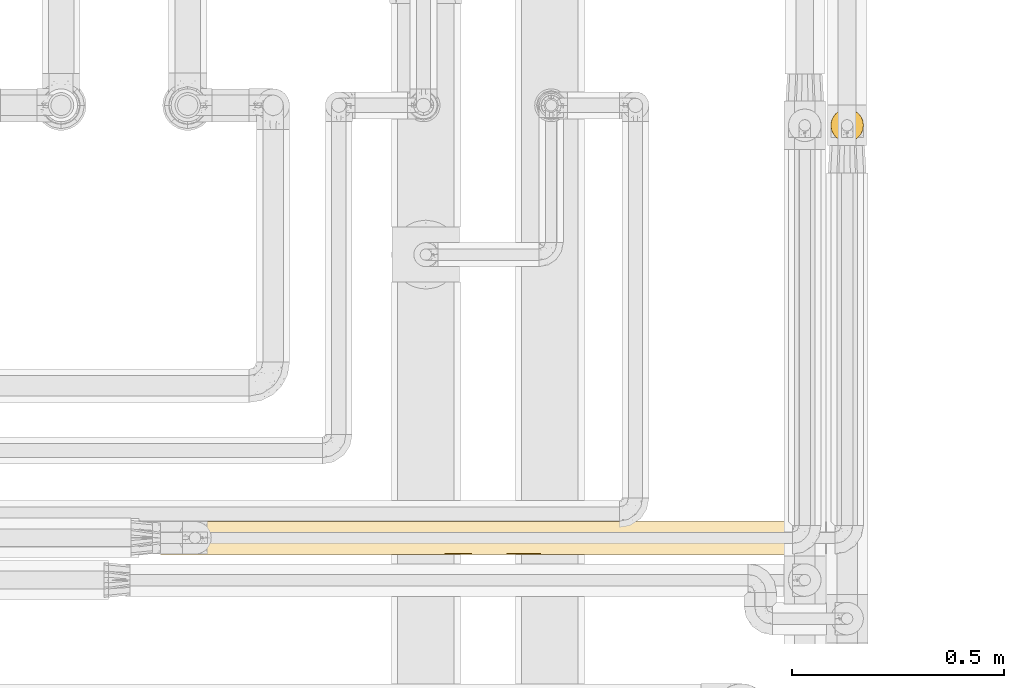
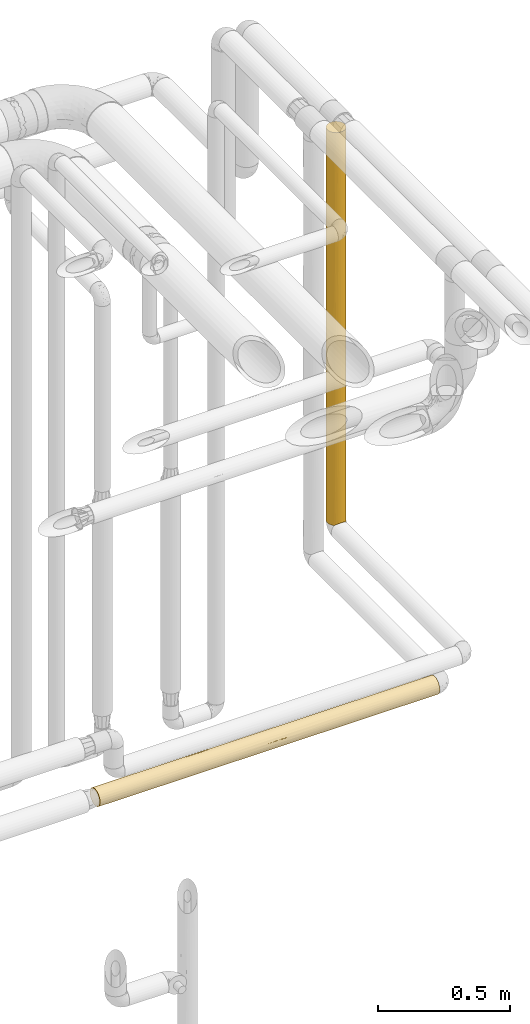
# One storey, part 50 of 827: 2 coverings.
"""IFC2X3 building model written with IfcOpenShell, lengths in millimetres."""

from ifc_helpers import new_model, entity, si_unit, converted_unit, derived_unit, direction, frame, origin, place, context, subcontext, project, spatial, faceted_brep, element, save


model = new_model("IFC2X3")

# Units and contexts
model_context = context("Model", 3, precision=0.01, world=origin(), true_north=direction((6.12303176911189e-17, 1.0)))
body_context = subcontext(model_context, "Body", "Model", "MODEL_VIEW")
ifc_project = project(units=[si_unit("LENGTHUNIT", "METRE", prefix="MILLI"), si_unit("AREAUNIT", "SQUARE_METRE"), si_unit("VOLUMEUNIT", "CUBIC_METRE"), converted_unit("PLANEANGLEUNIT", "DEGREE", entity("IfcRatioMeasure", 0.0174532925199433), si_unit("PLANEANGLEUNIT", "RADIAN"), dimensions=[0, 0, 0, 0, 0, 0, 0]), si_unit("MASSUNIT", "GRAM", prefix="KILO"), derived_unit("MASSDENSITYUNIT", [(si_unit("MASSUNIT", "GRAM", prefix="KILO"), 1), (si_unit("LENGTHUNIT", "METRE"), -3)]), derived_unit("MOMENTOFINERTIAUNIT", [(si_unit("LENGTHUNIT", "METRE"), 4)]), si_unit("TIMEUNIT", "SECOND"), si_unit("FREQUENCYUNIT", "HERTZ"), si_unit("THERMODYNAMICTEMPERATUREUNIT", "DEGREE_CELSIUS"), derived_unit("THERMALTRANSMITTANCEUNIT", [(si_unit("MASSUNIT", "GRAM", prefix="KILO"), 1), (si_unit("THERMODYNAMICTEMPERATUREUNIT", "KELVIN"), -1), (si_unit("TIMEUNIT", "SECOND"), -3)]), derived_unit("VOLUMETRICFLOWRATEUNIT", [(si_unit("LENGTHUNIT", "METRE"), 3), (si_unit("TIMEUNIT", "SECOND"), -1)]), derived_unit("MASSFLOWRATEUNIT", [(si_unit("MASSUNIT", "GRAM", prefix="KILO"), 1), (si_unit("TIMEUNIT", "SECOND"), -1)]), derived_unit("ROTATIONALFREQUENCYUNIT", [(si_unit("TIMEUNIT", "SECOND"), -1)]), si_unit("ELECTRICCURRENTUNIT", "AMPERE"), si_unit("ELECTRICVOLTAGEUNIT", "VOLT"), si_unit("POWERUNIT", "WATT"), si_unit("FORCEUNIT", "NEWTON", prefix="KILO"), si_unit("ILLUMINANCEUNIT", "LUX"), si_unit("LUMINOUSFLUXUNIT", "LUMEN"), si_unit("LUMINOUSINTENSITYUNIT", "CANDELA"), derived_unit("USERDEFINED", [(si_unit("MASSUNIT", "GRAM", prefix="KILO"), -1), (si_unit("LENGTHUNIT", "METRE"), -2), (si_unit("TIMEUNIT", "SECOND"), 3), (si_unit("LUMINOUSFLUXUNIT", "LUMEN"), 1)]), derived_unit("LINEARVELOCITYUNIT", [(si_unit("LENGTHUNIT", "METRE"), 1), (si_unit("TIMEUNIT", "SECOND"), -1)]), si_unit("PRESSUREUNIT", "PASCAL"), derived_unit("USERDEFINED", [(si_unit("LENGTHUNIT", "METRE"), -2), (si_unit("MASSUNIT", "GRAM", prefix="KILO"), 1), (si_unit("TIMEUNIT", "SECOND"), -2)]), derived_unit("LINEARFORCEUNIT", [(si_unit("MASSUNIT", "GRAM", prefix="KILO"), 1), (si_unit("LENGTHUNIT", "METRE"), 1), (si_unit("TIMEUNIT", "SECOND"), -2), (si_unit("LENGTHUNIT", "METRE"), -1)]), derived_unit("PLANARFORCEUNIT", [(si_unit("MASSUNIT", "GRAM", prefix="KILO"), 1), (si_unit("LENGTHUNIT", "METRE"), 1), (si_unit("TIMEUNIT", "SECOND"), -2), (si_unit("LENGTHUNIT", "METRE"), -2)])], contexts=[model_context])

# Site, building, storey
site_placement = place(None, origin())
site = spatial("IfcSite", under=ifc_project, at=site_placement, CompositionType="ELEMENT")
building_placement = place(site_placement, origin())
building = spatial("IfcBuilding", under=site, at=building_placement, CompositionType="ELEMENT")
storey_placement = place(building_placement, frame((0.0, 0.0, 28200.0)))
storey = spatial("IfcBuildingStorey", under=building, at=storey_placement, Name="08", CompositionType="ELEMENT", Elevation=28200.0)

# Coverings
covering_1_placement = place(storey_placement, frame((61112.64, 17412.84, 1127.5)))
element("IfcCovering", 1, at=covering_1_placement, inside=storey, Name=":ADSK_", ObjectType=":ADSK_", PredefinedType="INSULATION", context=body_context, shape_type="Brep", body=[
    faceted_brep([(2.48, 31.79, 1.6), (1.6, 40.0, 1.6), (2.9, 49.93, 1.6), (6.74, 59.2, 1.6), (12.84, 67.15, 1.6), (20.8, 73.25, 1.6), (30.06, 77.09, 1.6), (40.0, 78.4, 1.6), (49.93, 77.09, 1.6), (59.2, 73.25, 1.6), (67.15, 67.15, 1.6), (73.25, 59.2, 1.6), (77.09, 49.93, 1.6), (78.4, 40.0, 1.6), (77.51, 31.79, 1.6), (74.9, 23.98, 1.6), (70.68, 16.91, 1.6), (65.05, 10.9, 1.6), (14.94, 10.9, 1.6), (9.31, 16.91, 1.6), (5.09, 23.98, 1.6), (6.74, 20.8, 1824.24), (12.84, 12.84, 1824.24), (20.8, 6.74, 1824.24), (30.06, 2.9, 1824.24), (40.0, 1.6, 1824.24), (49.93, 2.9, 1824.24), (59.2, 6.74, 1824.24), (67.15, 12.84, 1824.24), (73.25, 20.8, 1824.24), (77.09, 30.06, 1824.24), (78.4, 40.0, 1824.24), (77.09, 49.93, 1824.24), (73.25, 59.2, 1824.24), (67.15, 67.15, 1824.24), (59.2, 73.25, 1824.24), (49.93, 77.09, 1824.24), (40.0, 78.4, 1824.24), (30.06, 77.09, 1824.24), (20.8, 73.25, 1824.24), (12.84, 67.15, 1824.24), (6.74, 59.2, 1824.24), (2.9, 49.93, 1824.24), (1.6, 40.0, 1824.24), (2.9, 30.06, 1824.24), (70.46, 16.62, 1571.65), (48.24, 2.49, 335.45), (50.46, 3.05, 688.07), (40.0, 1.6, 443.64), (40.0, 1.6, 1607.87), (47.32, 2.3, 1499.68), (70.46, 16.62, 1236.43), (63.37, 9.53, 1542.38), (62.5, 8.88, 1222.44), (77.74, 32.94, 1499.68), (75.47, 25.3, 1476.79), (53.24, 3.95, 1628.84), (67.73, 13.43, 544.14), (68.03, 13.75, 287.24), (72.98, 20.33, 485.18), (76.41, 27.82, 287.23), (74.66, 23.47, 675.76), (77.14, 30.25, 616.82), (72.98, 20.33, 218.66), (53.36, 4.0, 8.5), (59.51, 6.92, 5.57), (62.48, 8.86, 194.06), (67.04, 12.73, 973.09), (62.77, 9.08, 717.19), (68.28, 14.03, 761.11), (63.21, 9.41, 406.86), (40.0, 1.6, 1391.49), (48.72, 2.6, 1275.86), (51.06, 3.22, 1059.26), (54.69, 4.52, 1413.92), (46.78, 2.2, 10.29), (78.4, 40.0, 217.97), (78.4, 40.0, 1391.49), (77.14, 30.27, 1124.85), (40.0, 1.6, 227.27), (40.0, 1.6, 10.9), (40.0, 1.6, 876.39), (40.0, 1.6, 660.01), (56.68, 5.41, 384.99), (78.4, 40.0, 434.34), (73.3, 20.88, 875.08), (74.73, 23.63, 1245.66), (78.4, 40.0, 1607.87), (57.11, 5.62, 606.06), (59.51, 6.92, 967.7), (78.4, 40.0, 650.71), (78.4, 40.0, 696.55), (78.4, 40.0, 867.09), (78.4, 40.0, 958.74), (78.4, 40.0, 1129.29), (78.4, 40.0, 1175.12), (76.8, 29.04, 870.88), (40.0, 1.6, 1133.94), (32.67, 2.3, 1499.68), (26.75, 3.95, 1628.84), (25.3, 4.52, 1413.92), (12.95, 12.73, 973.09), (20.48, 6.92, 967.7), (17.49, 8.88, 1222.44), (22.88, 5.62, 606.06), (29.53, 3.05, 688.07), (16.62, 9.53, 1542.38), (9.53, 16.62, 1571.65), (9.53, 16.62, 1236.43), (26.63, 4.0, 8.5), (23.31, 5.41, 384.99), (17.51, 8.86, 194.06), (7.01, 20.33, 218.66), (31.75, 2.49, 335.45), (33.21, 2.2, 10.29), (16.78, 9.41, 406.86), (11.96, 13.75, 287.24), (2.61, 31.21, 870.8), (6.69, 20.88, 875.08), (5.79, 22.54, 1108.16), (3.58, 27.82, 287.23), (1.6, 40.0, 217.97), (2.25, 32.94, 1499.68), (2.85, 30.27, 1124.85), (4.52, 25.3, 1476.79), (28.93, 3.22, 1059.26), (12.26, 13.43, 544.14), (7.01, 20.33, 485.18), (31.27, 2.6, 1275.86), (2.85, 30.25, 616.82), (1.6, 40.0, 434.34), (17.22, 9.08, 717.19), (1.6, 40.0, 1391.49), (1.6, 40.0, 1607.87), (20.48, 6.92, 5.57), (5.33, 23.47, 675.76), (1.6, 40.0, 650.72), (11.71, 14.03, 761.11), (1.6, 40.0, 1129.29), (1.6, 40.0, 867.09), (9.53, 63.37, 1565.05), (16.62, 70.46, 1499.97), (4.52, 54.69, 1413.92), (2.49, 48.23, 1238.28), (2.3, 47.32, 1499.68), (25.3, 75.47, 1579.18), (3.95, 53.24, 1628.84), (40.0, 78.4, 1607.87), (40.0, 78.4, 217.97), (4.52, 54.69, 246.65), (2.29, 47.28, 326.15), (4.52, 54.69, 531.31), (16.62, 70.46, 260.79), (3.65, 52.37, 888.05), (32.71, 77.7, 1499.68), (25.3, 75.47, 1294.52), (9.53, 63.37, 325.87), (2.22, 46.88, 563.24), (8.3, 61.67, 762.65), (32.95, 77.74, 326.15), (33.13, 77.78, 562.99), (40.0, 78.4, 434.34), (28.01, 76.48, 1025.81), (17.82, 71.35, 1070.8), (25.3, 75.47, 341.66), (33.12, 77.77, 1262.59), (26.28, 75.86, 545.41), (28.01, 76.48, 744.48), (10.7, 64.83, 555.93), (16.62, 70.46, 571.22), (18.56, 71.86, 1290.13), (9.53, 63.37, 1082.61), (5.19, 56.22, 1163.74), (8.44, 61.88, 1323.83), (19.89, 72.71, 812.99), (13.25, 67.55, 884.51), (40.0, 78.4, 696.54), (40.0, 78.4, 650.71), (13.1, 67.4, 1339.61), (40.0, 78.4, 1391.49), (40.0, 78.4, 1175.12), (40.0, 78.4, 1129.29), (40.0, 78.4, 958.74), (40.0, 78.4, 867.09), (63.37, 70.46, 1565.05), (70.46, 63.37, 1499.97), (54.69, 75.47, 1413.92), (48.23, 77.5, 1238.28), (47.32, 77.69, 1499.68), (75.47, 54.69, 1579.18), (53.24, 76.04, 1628.84), (54.69, 75.47, 246.65), (47.28, 77.7, 326.15), (54.69, 75.47, 531.31), (70.46, 63.37, 260.79), (52.37, 76.35, 888.05), (77.7, 47.28, 1499.68), (75.47, 54.69, 1294.52), (63.37, 70.46, 325.87), (46.88, 77.77, 563.24), (61.67, 71.69, 762.65), (77.74, 47.04, 326.15), (77.78, 46.86, 562.99), (76.48, 51.98, 1025.81), (71.35, 62.17, 1070.8), (75.47, 54.69, 341.66), (77.77, 46.88, 1262.59), (75.86, 53.71, 545.41), (76.48, 51.98, 744.48), (64.83, 69.29, 555.93), (70.46, 63.37, 571.22), (71.86, 61.43, 1290.13), (63.37, 70.46, 1082.61), (56.22, 74.8, 1163.74), (61.88, 71.55, 1323.83), (72.71, 60.1, 812.99), (67.55, 66.74, 884.51), (67.4, 66.89, 1339.61)], [[[0, 1, 2, 3, 4, 5, 6, 7, 8, 9, 10, 11, 12, 13, 14, 15, 16, 17, 18, 19, 20]], [[21, 22, 23, 24, 25, 26, 27, 28, 29, 30, 31, 32, 33, 34, 35, 36, 37, 38, 39, 40, 41, 42, 43, 44]], [[29, 28, 45]], [[46, 47, 48]], [[49, 50, 26]], [[51, 52, 53]], [[54, 30, 55]], [[26, 50, 56]], [[57, 58, 59]], [[52, 45, 28]], [[60, 15, 14]], [[61, 59, 62]], [[60, 63, 15]], [[29, 55, 30]], [[64, 65, 66]], [[67, 68, 69]], [[70, 58, 57]], [[71, 50, 49]], [[72, 73, 74]], [[75, 64, 46]], [[59, 60, 62]], [[70, 66, 58]], [[14, 13, 76]], [[16, 63, 58]], [[52, 27, 56]], [[16, 58, 17]], [[63, 59, 58]], [[77, 54, 78]], [[79, 80, 75]], [[47, 73, 81]], [[27, 52, 28]], [[82, 48, 47, 81]], [[46, 64, 83]], [[48, 79, 46]], [[66, 65, 17]], [[60, 76, 84]], [[62, 60, 84]], [[85, 78, 86]], [[30, 54, 87]], [[75, 46, 79]], [[46, 83, 47]], [[83, 88, 47]], [[89, 67, 53]], [[53, 52, 74]], [[45, 51, 55]], [[62, 84, 90, 91, 92]], [[78, 92, 93, 94, 95, 77]], [[96, 92, 78]], [[67, 51, 53]], [[47, 88, 89]], [[14, 76, 60]], [[50, 72, 74]], [[74, 73, 53]], [[67, 89, 68]], [[51, 45, 52]], [[55, 29, 45]], [[69, 68, 57]], [[85, 51, 67]], [[53, 73, 89]], [[47, 89, 73]], [[26, 25, 49]], [[97, 72, 71]], [[50, 74, 56]], [[73, 97, 81]], [[71, 72, 50]], [[97, 73, 72]], [[52, 56, 74]], [[27, 26, 56]], [[87, 54, 77]], [[87, 31, 30]], [[55, 86, 54]], [[51, 86, 55]], [[96, 78, 85]], [[59, 61, 69]], [[68, 88, 70]], [[68, 70, 57]], [[83, 64, 66]], [[58, 66, 17]], [[83, 66, 70]], [[59, 69, 57]], [[85, 67, 69]], [[15, 63, 16]], [[59, 63, 60]], [[70, 88, 83]], [[89, 88, 68]], [[96, 61, 62]], [[69, 61, 85]], [[85, 86, 51]], [[54, 86, 78]], [[61, 96, 85]], [[92, 96, 62]], [[98, 99, 100]], [[101, 102, 103]], [[49, 25, 24]], [[102, 104, 105]], [[106, 23, 22]], [[106, 22, 107]], [[108, 106, 107]], [[109, 110, 111]], [[112, 20, 19]], [[79, 113, 114]], [[115, 111, 110]], [[18, 116, 19]], [[117, 118, 119]], [[120, 121, 0]], [[79, 48, 113]], [[122, 123, 124]], [[105, 125, 102]], [[20, 120, 0]], [[124, 21, 44]], [[112, 19, 116]], [[116, 126, 127]], [[127, 120, 112]], [[100, 128, 98]], [[100, 99, 106]], [[24, 99, 98]], [[120, 129, 130]], [[101, 131, 102]], [[132, 122, 133]], [[109, 114, 113]], [[113, 105, 110]], [[111, 18, 134]], [[115, 131, 126]], [[129, 120, 127]], [[0, 121, 1]], [[44, 133, 122]], [[132, 123, 122]], [[114, 80, 79]], [[105, 48, 82, 81]], [[113, 110, 109]], [[125, 105, 81]], [[104, 110, 105]], [[22, 21, 107]], [[103, 106, 108]], [[135, 129, 127]], [[117, 136, 129]], [[127, 126, 137]], [[124, 123, 119]], [[71, 98, 128]], [[130, 121, 120]], [[100, 106, 103]], [[103, 108, 101]], [[125, 100, 103]], [[21, 124, 107]], [[108, 107, 124]], [[119, 101, 108]], [[131, 137, 126]], [[102, 131, 104]], [[125, 103, 102]], [[24, 98, 49]], [[71, 49, 98]], [[125, 81, 97]], [[128, 100, 125]], [[125, 97, 128]], [[71, 128, 97]], [[24, 23, 99]], [[106, 99, 23]], [[44, 43, 133]], [[123, 132, 138]], [[44, 122, 124]], [[117, 138, 139, 136]], [[123, 117, 119]], [[115, 126, 116]], [[131, 101, 137]], [[116, 18, 111]], [[115, 110, 104]], [[111, 134, 109]], [[116, 111, 115]], [[101, 118, 137]], [[137, 118, 135]], [[127, 112, 116]], [[20, 112, 120]], [[48, 105, 113]], [[115, 104, 131]], [[137, 135, 127]], [[136, 130, 129]], [[117, 135, 118]], [[117, 129, 135]], [[138, 117, 123]], [[101, 119, 118]], [[124, 119, 108]], [[140, 40, 141]], [[142, 143, 144]], [[133, 43, 42]], [[2, 1, 121]], [[41, 40, 140]], [[39, 145, 141]], [[146, 142, 144]], [[38, 37, 147]], [[6, 148, 7]], [[149, 150, 151]], [[5, 4, 152]], [[39, 38, 145]], [[153, 139, 138]], [[145, 154, 155]], [[3, 156, 4]], [[151, 157, 153]], [[156, 152, 4]], [[42, 146, 144]], [[151, 153, 158]], [[159, 160, 161]], [[3, 2, 149]], [[155, 162, 163]], [[156, 3, 149]], [[5, 164, 6]], [[165, 162, 155]], [[39, 141, 40]], [[159, 6, 164]], [[160, 166, 167]], [[168, 151, 158]], [[151, 150, 157]], [[152, 169, 164]], [[163, 170, 155]], [[155, 154, 165]], [[171, 172, 173]], [[174, 175, 163]], [[160, 176, 177, 161]], [[152, 156, 168]], [[164, 5, 152]], [[170, 178, 141]], [[146, 140, 142]], [[121, 150, 2]], [[156, 149, 151]], [[147, 154, 38]], [[145, 155, 170]], [[150, 121, 130]], [[150, 130, 157]], [[2, 150, 149]], [[157, 130, 136, 139]], [[153, 157, 139]], [[143, 132, 144]], [[158, 153, 171]], [[154, 147, 179]], [[154, 179, 165]], [[38, 154, 145]], [[162, 180, 181, 182]], [[162, 182, 167]], [[165, 180, 162]], [[166, 174, 167]], [[162, 167, 174]], [[173, 178, 171]], [[165, 179, 180]], [[6, 159, 148]], [[161, 148, 159]], [[167, 182, 183, 176]], [[166, 160, 159]], [[166, 159, 164]], [[176, 160, 167]], [[42, 144, 133]], [[132, 133, 144]], [[132, 143, 138]], [[172, 153, 143]], [[172, 143, 142]], [[153, 138, 143]], [[173, 142, 140]], [[153, 172, 171]], [[142, 173, 172]], [[178, 140, 141]], [[42, 41, 146]], [[140, 146, 41]], [[175, 171, 163]], [[168, 169, 152]], [[164, 169, 166]], [[174, 166, 169]], [[169, 168, 175]], [[162, 174, 163]], [[169, 175, 174]], [[171, 175, 158]], [[163, 171, 178]], [[145, 170, 141]], [[178, 170, 163]], [[140, 178, 173]], [[151, 168, 156]], [[175, 168, 158]], [[184, 34, 185]], [[186, 187, 188]], [[147, 37, 36]], [[8, 7, 148]], [[35, 34, 184]], [[33, 189, 185]], [[190, 186, 188]], [[32, 31, 87]], [[12, 76, 13]], [[191, 192, 193]], [[11, 10, 194]], [[33, 32, 189]], [[195, 183, 182, 181]], [[189, 196, 197]], [[9, 198, 10]], [[193, 199, 195]], [[198, 194, 10]], [[36, 190, 188]], [[193, 195, 200]], [[201, 202, 84]], [[9, 8, 191]], [[197, 203, 204]], [[198, 9, 191]], [[11, 205, 12]], [[206, 203, 197]], [[33, 185, 34]], [[201, 12, 205]], [[202, 207, 208]], [[209, 193, 200]], [[193, 192, 199]], [[194, 210, 205]], [[204, 211, 197]], [[197, 196, 206]], [[212, 213, 214]], [[215, 216, 204]], [[202, 91, 90, 84]], [[194, 198, 209]], [[205, 11, 194]], [[211, 217, 185]], [[190, 184, 186]], [[148, 192, 8]], [[198, 191, 193]], [[87, 196, 32]], [[189, 197, 211]], [[192, 148, 161]], [[192, 161, 199]], [[8, 192, 191]], [[199, 161, 177, 176, 183]], [[195, 199, 183]], [[187, 179, 188]], [[200, 195, 212]], [[196, 87, 77]], [[196, 77, 206]], [[32, 196, 189]], [[203, 95, 94, 93]], [[203, 93, 208]], [[206, 95, 203]], [[207, 215, 208]], [[203, 208, 215]], [[214, 217, 212]], [[206, 77, 95]], [[12, 201, 76]], [[84, 76, 201]], [[208, 93, 92, 91]], [[207, 202, 201]], [[207, 201, 205]], [[91, 202, 208]], [[36, 188, 147]], [[179, 147, 188]], [[187, 181, 180, 179]], [[213, 195, 187]], [[213, 187, 186]], [[195, 181, 187]], [[214, 186, 184]], [[195, 213, 212]], [[186, 214, 213]], [[217, 184, 185]], [[36, 35, 190]], [[184, 190, 35]], [[216, 212, 204]], [[209, 210, 194]], [[205, 210, 207]], [[215, 207, 210]], [[210, 209, 216]], [[203, 215, 204]], [[210, 216, 215]], [[212, 216, 200]], [[204, 212, 217]], [[189, 211, 185]], [[217, 211, 204]], [[184, 217, 214]], [[193, 209, 198]], [[216, 209, 200]], [[65, 64, 75, 80, 114, 109, 134, 18, 17]]]),
])
covering_2_placement = place(storey_placement, frame((59532.64, 16439.16, 960.01)))
element("IfcCovering", 2, at=covering_2_placement, inside=storey, Name=":ADSK_", ObjectType=":ADSK_", PredefinedType="INSULATION", context=body_context, shape_type="Brep", body=[
    faceted_brep([(1490.9, 56.0, 5.1), (1490.9, 63.07, 9.31), (1490.9, 69.09, 14.94), (1490.9, 69.1, 65.05), (1490.9, 63.09, 70.68), (1490.9, 56.01, 74.9), (1490.9, 48.2, 77.52), (1490.9, 40.0, 78.41), (1490.9, 30.06, 77.1), (1490.9, 20.8, 73.26), (1490.9, 12.84, 67.16), (1490.9, 6.74, 59.21), (1490.9, 2.9, 49.94), (1490.9, 1.6, 40.01), (1490.9, 2.9, 30.07), (1490.9, 6.74, 20.81), (1490.9, 12.84, 12.85), (1490.9, 20.8, 6.75), (1490.9, 30.06, 2.91), (1490.9, 40.0, 1.61), (1490.9, 48.19, 2.49), (0.0, 77.09, 30.06), (0.0, 73.25, 20.8), (0.0, 67.15, 12.84), (0.0, 59.2, 6.74), (0.0, 49.93, 2.9), (0.0, 40.0, 1.6), (0.0, 30.06, 2.9), (0.0, 20.8, 6.74), (0.0, 12.84, 12.84), (0.0, 6.74, 20.8), (0.0, 2.9, 30.06), (0.0, 1.6, 40.0), (0.0, 2.9, 49.93), (0.0, 6.74, 59.2), (0.0, 12.84, 67.15), (0.0, 20.8, 73.25), (0.0, 30.06, 77.09), (0.0, 40.0, 78.4), (0.0, 49.93, 77.09), (0.0, 59.2, 73.25), (0.0, 67.15, 67.15), (0.0, 73.25, 59.2), (0.0, 77.09, 49.93), (0.0, 78.4, 40.0), (621.65, 2.42, 32.07), (432.75, 1.6, 40.0), (324.56, 2.29, 32.71), (216.92, 23.64, 5.25), (293.88, 16.62, 9.53), (1044.39, 2.2, 33.19), (1256.48, 2.97, 29.81), (1178.2, 1.6, 40.0), (254.03, 9.53, 16.62), (216.37, 1.6, 40.0), (929.25, 33.12, 2.22), (1058.15, 40.0, 1.6), (1166.34, 32.71, 2.3), (1166.63, 16.62, 9.54), (194.65, 3.89, 26.92), (405.32, 4.52, 25.3), (723.66, 9.53, 16.62), (488.85, 8.27, 18.36), (616.44, 17.03, 9.22), (1231.71, 9.53, 16.63), (977.68, 11.65, 14.1), (1245.85, 25.3, 4.53), (1274.53, 40.0, 1.6), (258.63, 31.23, 2.61), (216.37, 40.0, 1.6), (312.7, 40.0, 1.6), (1266.8, 5.63, 22.86), (873.34, 6.31, 21.57), (654.04, 5.17, 23.83), (961.18, 25.3, 4.52), (845.61, 3.28, 28.76), (514.88, 32.8, 2.28), (924.54, 17.91, 8.59), (446.9, 25.3, 4.52), (704.04, 28.06, 3.5), (625.41, 40.0, 1.6), (1066.26, 4.52, 25.31), (865.49, 1.6, 40.0), (841.78, 40.0, 1.6), (649.12, 1.6, 40.0), (432.75, 40.0, 1.6), (249.73, 54.69, 4.52), (1048.85, 78.4, 40.0), (1265.23, 78.4, 40.0), (1157.04, 77.5, 31.76), (1085.75, 70.58, 16.78), (1205.28, 66.23, 11.96), (948.33, 66.55, 12.26), (804.4, 76.94, 29.54), (542.6, 77.58, 32.14), (616.11, 78.4, 40.0), (1484.0, 75.99, 26.64), (1107.35, 74.58, 23.31), (185.29, 75.47, 25.3), (285.09, 70.46, 16.62), (529.08, 52.32, 3.63), (1205.28, 52.17, 3.58), (1007.28, 59.65, 7.01), (324.56, 47.25, 2.29), (194.13, 63.37, 9.53), (1273.91, 59.65, 7.02), (875.94, 49.74, 2.86), (1481.6, 78.4, 40.01), (1482.2, 77.79, 33.21), (721.84, 61.55, 8.22), (775.02, 70.9, 17.21), (1298.51, 71.12, 17.51), (308.05, 78.4, 40.0), (302.89, 77.55, 31.97), (1486.93, 73.06, 20.48), (886.17, 74.37, 22.88), (648.59, 74.52, 23.18), (420.48, 75.47, 25.3), (530.18, 70.63, 16.84), (436.34, 63.37, 9.53), (832.48, 78.4, 40.0), (285.09, 70.46, 63.37), (1085.53, 70.59, 63.21), (775.59, 70.92, 62.77), (948.38, 66.56, 67.73), (302.9, 77.55, 48.03), (542.61, 77.58, 47.86), (185.3, 75.47, 54.69), (1298.36, 71.13, 62.48), (1486.93, 73.07, 59.51), (1107.66, 74.59, 56.68), (420.49, 75.47, 54.69), (1484.0, 76.0, 53.36), (194.42, 63.37, 70.46), (1157.04, 77.5, 48.24), (1482.21, 77.79, 46.79), (1205.23, 66.25, 68.03), (1205.24, 52.18, 76.42), (1274.53, 40.0, 78.4), (804.46, 76.94, 50.46), (722.19, 61.57, 71.77), (1007.35, 59.67, 72.98), (875.42, 49.75, 77.14), (625.41, 40.0, 78.4), (841.78, 40.0, 78.4), (1058.15, 40.0, 78.4), (654.23, 74.63, 56.58), (249.74, 54.69, 75.47), (1273.77, 59.67, 72.98), (529.08, 52.32, 76.37), (530.01, 70.85, 62.86), (867.23, 74.4, 57.06), (432.75, 40.0, 78.4), (324.56, 47.25, 77.71), (216.37, 40.0, 78.4), (436.88, 63.37, 70.46), (312.7, 40.0, 78.4), (259.19, 16.62, 70.46), (324.27, 9.53, 63.37), (1085.58, 25.3, 75.48), (1166.34, 32.71, 77.71), (869.25, 32.07, 77.57), (424.64, 25.3, 75.48), (224.1, 22.85, 74.36), (645.29, 28.76, 76.72), (446.51, 33.19, 77.79), (617.56, 21.57, 73.69), (836.86, 23.82, 74.83), (786.86, 3.5, 51.93), (976.02, 2.28, 47.2), (1044.0, 4.52, 54.7), (1236.87, 16.62, 70.47), (1197.03, 9.53, 63.38), (566.36, 8.58, 62.09), (513.22, 14.09, 68.34), (245.05, 4.52, 54.69), (324.56, 2.29, 47.28), (529.72, 4.52, 54.69), (1002.05, 18.35, 71.72), (874.46, 9.22, 62.97), (561.65, 2.22, 46.88), (1273.98, 5.25, 56.36), (1232.27, 2.61, 48.76), (1296.25, 26.92, 76.11), (234.42, 29.8, 77.02), (767.24, 16.62, 70.47)], [[[0, 1, 2, 3, 4, 5, 6, 7, 8, 9, 10, 11, 12, 13, 14, 15, 16, 17, 18, 19, 20]], [[21, 22, 23, 24, 25, 26, 27, 28, 29, 30, 31, 32, 33, 34, 35, 36, 37, 38, 39, 40, 41, 42, 43, 44]], [[45, 46, 47]], [[48, 49, 28]], [[50, 51, 52]], [[29, 53, 30]], [[54, 47, 46]], [[55, 56, 57]], [[58, 17, 16]], [[47, 59, 60]], [[13, 52, 51]], [[61, 62, 63]], [[64, 65, 58]], [[18, 17, 66]], [[57, 56, 67]], [[16, 64, 58]], [[29, 28, 49]], [[68, 26, 69, 70]], [[31, 59, 47]], [[71, 14, 51]], [[61, 72, 73]], [[27, 68, 48]], [[58, 74, 66]], [[75, 45, 73]], [[31, 47, 54]], [[70, 76, 68]], [[16, 15, 64]], [[53, 29, 49]], [[18, 67, 19]], [[77, 74, 58]], [[63, 49, 78]], [[79, 76, 80]], [[53, 62, 60]], [[81, 71, 51]], [[50, 82, 75]], [[72, 65, 64]], [[49, 63, 62]], [[59, 53, 60]], [[58, 66, 17]], [[57, 18, 66]], [[79, 63, 78]], [[77, 58, 65]], [[72, 64, 81]], [[77, 61, 63]], [[74, 55, 57]], [[18, 57, 67]], [[74, 57, 66]], [[79, 55, 74]], [[79, 83, 55]], [[79, 74, 77]], [[79, 78, 76]], [[61, 77, 65]], [[79, 77, 63]], [[83, 79, 80]], [[83, 56, 55]], [[54, 32, 31]], [[45, 47, 60]], [[45, 60, 73]], [[45, 82, 84, 46]], [[31, 30, 59]], [[53, 59, 30]], [[68, 76, 78]], [[76, 70, 85, 80]], [[48, 68, 78]], [[26, 68, 27]], [[49, 48, 78]], [[27, 48, 28]], [[62, 73, 60]], [[75, 72, 81]], [[50, 75, 81]], [[82, 45, 75]], [[51, 50, 81]], [[82, 50, 52]], [[81, 64, 71]], [[51, 14, 13]], [[73, 72, 75]], [[65, 72, 61]], [[64, 15, 71]], [[14, 71, 15]], [[62, 53, 49]], [[73, 62, 61]], [[25, 24, 86]], [[87, 88, 89]], [[90, 91, 92]], [[93, 94, 95]], [[89, 96, 97]], [[22, 98, 99]], [[20, 19, 67]], [[80, 85, 100]], [[101, 0, 20]], [[92, 91, 102]], [[103, 85, 70, 69]], [[24, 23, 104]], [[91, 1, 105]], [[105, 102, 91]], [[101, 105, 0]], [[101, 106, 102]], [[88, 107, 108]], [[108, 96, 89]], [[109, 110, 92]], [[90, 111, 91]], [[112, 113, 44]], [[21, 98, 22]], [[89, 93, 87]], [[1, 91, 2]], [[111, 96, 114]], [[22, 99, 23]], [[93, 115, 116]], [[117, 118, 99]], [[113, 117, 98]], [[106, 80, 100]], [[111, 114, 2]], [[101, 67, 56]], [[106, 101, 56]], [[108, 89, 88]], [[89, 97, 93]], [[115, 93, 97]], [[113, 94, 117]], [[119, 100, 86]], [[26, 25, 69]], [[100, 119, 109]], [[117, 116, 118]], [[104, 99, 119]], [[106, 56, 83, 80]], [[112, 94, 113]], [[109, 106, 100]], [[86, 24, 104]], [[20, 67, 101]], [[103, 25, 86]], [[103, 100, 85]], [[25, 103, 69]], [[100, 103, 86]], [[99, 104, 23]], [[86, 104, 119]], [[109, 92, 102]], [[110, 115, 90]], [[109, 102, 106]], [[109, 119, 118]], [[110, 90, 92]], [[97, 96, 111]], [[91, 111, 2]], [[97, 111, 90]], [[21, 44, 113]], [[99, 98, 117]], [[21, 113, 98]], [[94, 112, 95]], [[120, 87, 93, 95]], [[116, 94, 93]], [[0, 105, 1]], [[102, 105, 101]], [[90, 115, 97]], [[116, 115, 110]], [[116, 110, 118]], [[116, 117, 94]], [[109, 118, 110]], [[119, 99, 118]], [[41, 121, 42]], [[122, 123, 124]], [[112, 125, 126]], [[127, 125, 43]], [[128, 3, 129]], [[128, 130, 122]], [[121, 131, 127]], [[132, 130, 128]], [[41, 40, 133]], [[88, 134, 135]], [[127, 43, 42]], [[3, 136, 4]], [[134, 88, 87]], [[137, 138, 6]], [[134, 139, 130]], [[124, 140, 141]], [[142, 143, 144, 145]], [[126, 146, 139]], [[39, 147, 40]], [[136, 148, 4]], [[136, 124, 141]], [[148, 5, 4]], [[5, 137, 6]], [[140, 149, 142]], [[145, 137, 142]], [[146, 150, 123]], [[132, 135, 134]], [[141, 137, 148]], [[146, 123, 151]], [[149, 152, 143]], [[142, 137, 141]], [[6, 138, 7]], [[135, 107, 88]], [[95, 126, 139]], [[134, 130, 132]], [[95, 112, 126]], [[151, 139, 146]], [[153, 149, 147]], [[39, 38, 154]], [[133, 147, 155]], [[133, 121, 41]], [[155, 140, 150]], [[140, 142, 141]], [[43, 125, 44]], [[143, 142, 149]], [[154, 153, 39]], [[145, 138, 137]], [[155, 147, 149]], [[153, 154, 156, 152]], [[149, 153, 152]], [[39, 153, 147]], [[147, 133, 40]], [[121, 133, 155]], [[122, 124, 136]], [[123, 150, 140]], [[123, 140, 124]], [[149, 140, 155]], [[136, 3, 128]], [[122, 130, 151]], [[128, 129, 132]], [[136, 128, 122]], [[121, 127, 42]], [[125, 127, 131]], [[125, 131, 126]], [[125, 112, 44]], [[146, 126, 131]], [[139, 87, 120, 95]], [[141, 148, 136]], [[5, 148, 137]], [[87, 139, 134]], [[150, 131, 121]], [[131, 150, 146]], [[155, 150, 121]], [[122, 151, 123]], [[130, 139, 151]], [[157, 35, 158]], [[159, 160, 161]], [[8, 138, 160]], [[36, 35, 157]], [[157, 162, 163]], [[164, 165, 162]], [[33, 32, 54]], [[164, 166, 167]], [[161, 167, 159]], [[168, 169, 170]], [[171, 172, 10]], [[158, 173, 174]], [[175, 176, 177]], [[172, 178, 179]], [[180, 168, 177]], [[181, 170, 182]], [[183, 8, 160]], [[34, 33, 175]], [[34, 158, 35]], [[170, 172, 179]], [[172, 170, 181]], [[169, 182, 170]], [[11, 10, 172]], [[145, 160, 138]], [[184, 162, 165]], [[175, 158, 34]], [[177, 176, 180]], [[166, 157, 174]], [[10, 9, 171]], [[12, 182, 13]], [[171, 178, 172]], [[174, 157, 158]], [[37, 184, 38]], [[163, 162, 184]], [[183, 171, 9]], [[178, 171, 159]], [[54, 176, 33]], [[158, 175, 177]], [[185, 174, 173]], [[179, 173, 168]], [[158, 177, 173]], [[174, 185, 166]], [[176, 54, 46]], [[176, 46, 180]], [[33, 176, 175]], [[168, 84, 82]], [[82, 169, 168]], [[180, 84, 168]], [[179, 168, 170]], [[168, 173, 177]], [[185, 173, 179]], [[180, 46, 84]], [[8, 7, 138]], [[161, 160, 145]], [[160, 159, 183]], [[161, 145, 144, 143]], [[164, 162, 166]], [[171, 183, 159]], [[9, 8, 183]], [[82, 52, 169]], [[182, 169, 52]], [[13, 182, 52]], [[181, 12, 11]], [[12, 181, 182]], [[172, 181, 11]], [[167, 161, 164]], [[178, 167, 185]], [[161, 143, 164]], [[165, 143, 152, 156]], [[143, 165, 164]], [[184, 156, 154, 38]], [[156, 184, 165]], [[163, 37, 36]], [[166, 162, 157]], [[167, 166, 185]], [[37, 163, 184]], [[36, 157, 163]], [[167, 178, 159]], [[179, 178, 185]], [[107, 135, 132, 129, 3, 2, 114, 96, 108]]]),
])

save(model, "model.ifc")
